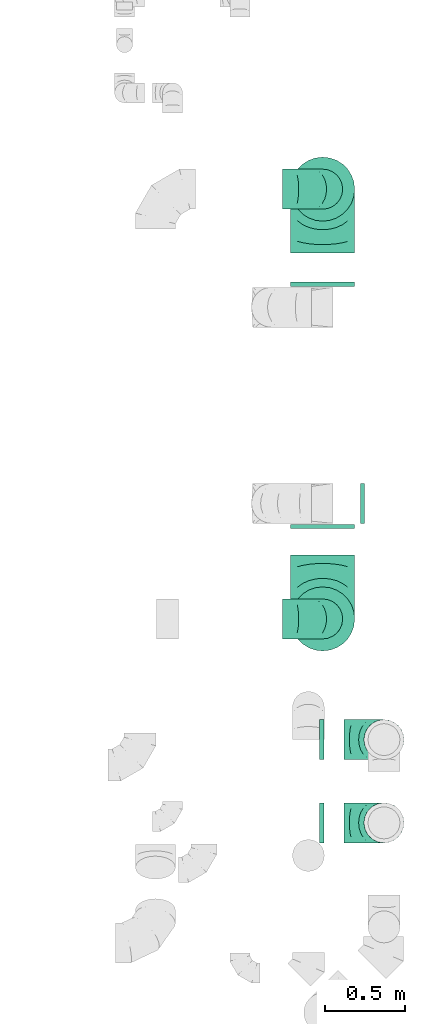
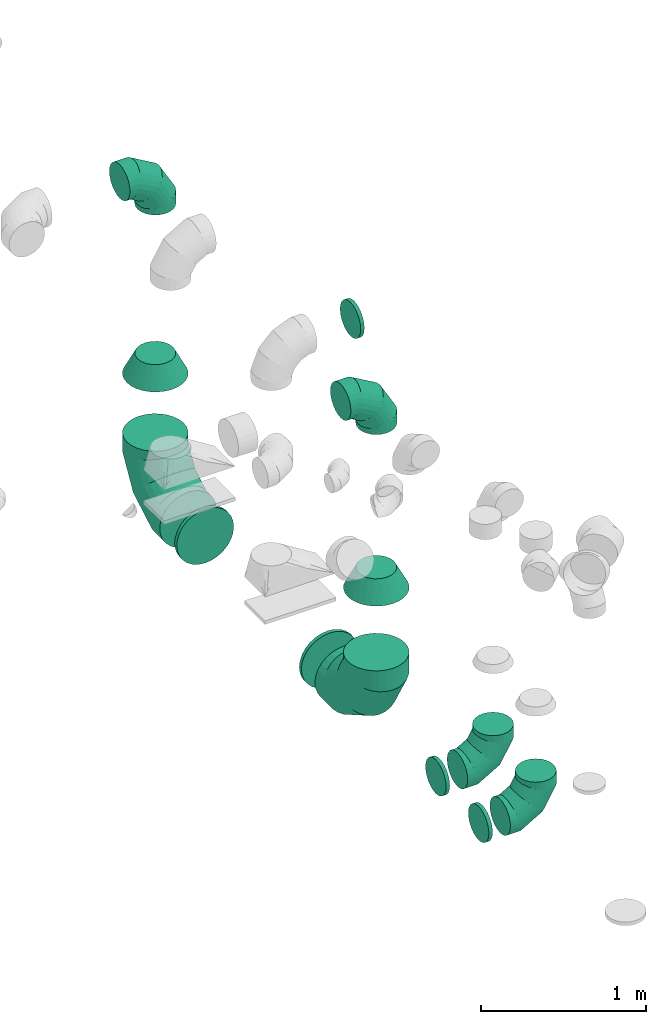
# One storey, part 48 of 59: 13 flow fittings.
"""IFC2X3 building model written with IfcOpenShell, lengths in millimetres."""

from ifc_helpers import new_model, entity, si_unit, converted_unit, derived_unit, direction, frame, origin, place, context, subcontext, project, spatial, faceted_brep, source, transform, mapped, material, type_object, type_shapes, element, save


model = new_model("IFC2X3")

# Units and contexts
model_context = context("Model", 3, precision=0.01, world=origin(), true_north=direction((6.12303176911189e-17, 1.0)))
body_context = subcontext(model_context, "Body", "Model", "MODEL_VIEW")
ifc_project = project(units=[si_unit("LENGTHUNIT", "METRE", prefix="MILLI"), si_unit("AREAUNIT", "SQUARE_METRE"), si_unit("VOLUMEUNIT", "CUBIC_METRE"), converted_unit("PLANEANGLEUNIT", "DEGREE", entity("IfcRatioMeasure", 0.0174532925199433), si_unit("PLANEANGLEUNIT", "RADIAN"), dimensions=[0, 0, 0, 0, 0, 0, 0]), si_unit("MASSUNIT", "GRAM", prefix="KILO"), derived_unit("MASSDENSITYUNIT", [(si_unit("MASSUNIT", "GRAM", prefix="KILO"), 1), (si_unit("LENGTHUNIT", "METRE"), -3)]), derived_unit("MOMENTOFINERTIAUNIT", [(si_unit("LENGTHUNIT", "METRE"), 4)]), si_unit("TIMEUNIT", "SECOND"), si_unit("FREQUENCYUNIT", "HERTZ"), si_unit("THERMODYNAMICTEMPERATUREUNIT", "DEGREE_CELSIUS"), derived_unit("THERMALTRANSMITTANCEUNIT", [(si_unit("MASSUNIT", "GRAM", prefix="KILO"), 1), (si_unit("THERMODYNAMICTEMPERATUREUNIT", "KELVIN"), -1), (si_unit("TIMEUNIT", "SECOND"), -3)]), derived_unit("VOLUMETRICFLOWRATEUNIT", [(si_unit("LENGTHUNIT", "METRE"), 3), (si_unit("TIMEUNIT", "SECOND"), -1)]), derived_unit("MASSFLOWRATEUNIT", [(si_unit("MASSUNIT", "GRAM", prefix="KILO"), 1), (si_unit("TIMEUNIT", "SECOND"), -1)]), derived_unit("ROTATIONALFREQUENCYUNIT", [(si_unit("TIMEUNIT", "SECOND"), -1)]), si_unit("ELECTRICCURRENTUNIT", "AMPERE"), si_unit("ELECTRICVOLTAGEUNIT", "VOLT"), si_unit("POWERUNIT", "WATT"), si_unit("FORCEUNIT", "NEWTON", prefix="KILO"), si_unit("ILLUMINANCEUNIT", "LUX"), si_unit("LUMINOUSFLUXUNIT", "LUMEN"), si_unit("LUMINOUSINTENSITYUNIT", "CANDELA"), derived_unit("USERDEFINED", [(si_unit("MASSUNIT", "GRAM", prefix="KILO"), -1), (si_unit("LENGTHUNIT", "METRE"), -2), (si_unit("TIMEUNIT", "SECOND"), 3), (si_unit("LUMINOUSFLUXUNIT", "LUMEN"), 1)]), derived_unit("LINEARVELOCITYUNIT", [(si_unit("LENGTHUNIT", "METRE"), 1), (si_unit("TIMEUNIT", "SECOND"), -1)]), si_unit("PRESSUREUNIT", "PASCAL"), derived_unit("USERDEFINED", [(si_unit("LENGTHUNIT", "METRE"), -2), (si_unit("MASSUNIT", "GRAM", prefix="KILO"), 1), (si_unit("TIMEUNIT", "SECOND"), -2)]), derived_unit("LINEARFORCEUNIT", [(si_unit("MASSUNIT", "GRAM", prefix="KILO"), 1), (si_unit("LENGTHUNIT", "METRE"), 1), (si_unit("TIMEUNIT", "SECOND"), -2), (si_unit("LENGTHUNIT", "METRE"), -1)]), derived_unit("PLANARFORCEUNIT", [(si_unit("MASSUNIT", "GRAM", prefix="KILO"), 1), (si_unit("LENGTHUNIT", "METRE"), 1), (si_unit("TIMEUNIT", "SECOND"), -2), (si_unit("LENGTHUNIT", "METRE"), -2)])], contexts=[model_context])

# Site, building, storey
site_placement = place(None, origin())
site = spatial("IfcSite", under=ifc_project, at=site_placement, CompositionType="ELEMENT")
building_placement = place(site_placement, origin())
building = spatial("IfcBuilding", under=site, at=building_placement, CompositionType="ELEMENT")
storey_placement = place(building_placement, frame((0.0, 0.0, 28200.0)))
storey = spatial("IfcBuildingStorey", under=building, at=storey_placement, CompositionType="ELEMENT", Elevation=28200.0)

# Flow fittings
ifc_material = material()
duct_fitting_type_1 = type_object("IfcDuctFittingType", PredefinedType="NOTDEFINED", material=ifc_material)
shared_shape_1 = source(origin(), body_context, "Body", "Brep", [
    faceted_brep([(-250.0, 0.0, -125.0), (-250.0, -32.35, -120.74), (-250.0, -62.5, -108.25), (-250.0, -88.39, -88.39), (-250.0, -108.25, -62.5), (-250.0, -120.74, -32.35), (-250.0, -125.0, 0.0), (-250.0, -120.74, 32.35), (-250.0, -108.25, 62.5), (-250.0, -88.39, 88.39), (-250.0, -62.5, 108.25), (-250.0, -32.35, 120.74), (-250.0, 0.0, 125.0), (-250.0, 32.35, 120.74), (-250.0, 62.5, 108.25), (-250.0, 88.39, 88.39), (-250.0, 108.25, 62.5), (-250.0, 120.74, 32.35), (-250.0, 125.0, 0.0), (-250.0, 120.74, -32.35), (-250.0, 108.25, -62.5), (-250.0, 88.39, -88.39), (-250.0, 62.5, -108.25), (-250.0, 32.35, -120.74), (-191.68, 32.35, 120.74), (-199.76, 62.5, 108.25), (-183.01, 0.0, 125.0), (-206.7, 88.39, 88.39), (-215.37, 120.74, 32.35), (-216.51, 125.0, 0.0), (-212.02, 108.25, 62.5), (-212.02, 108.25, -62.5), (-206.7, 88.39, -88.39), (-215.37, 120.74, -32.35), (-191.68, 32.35, -120.74), (-183.01, 0.0, -125.0), (-199.76, 62.5, -108.25), (-174.34, -32.35, -120.74), (-166.27, -62.5, -108.25), (-159.33, -88.39, -88.39), (-154.01, -108.25, -62.5), (-150.66, -120.74, -32.35), (-149.52, -125.0, 0.0), (-150.66, -120.74, 32.35), (-154.01, -108.25, 62.5), (-159.33, -88.39, 88.39), (-166.27, -62.5, 108.25), (-174.34, -32.35, 120.74), (-90.67, 90.67, 120.74), (-112.74, 112.74, 108.25), (-66.99, 66.99, 125.0), (-131.69, 131.69, 88.39), (-146.23, 146.23, 62.5), (-155.38, 155.38, 32.35), (-158.49, 158.49, 0.0), (-155.38, 155.38, -32.35), (-146.23, 146.23, -62.5), (-131.69, 131.69, -88.39), (-90.67, 90.67, -120.74), (-66.99, 66.99, -125.0), (-112.74, 112.74, -108.25), (-43.3, 43.3, -120.74), (-21.23, 21.23, -108.25), (-2.28, 2.28, -88.39), (12.26, -12.26, -62.5), (21.4, -21.4, -32.35), (24.52, -24.52, 0.0), (21.4, -21.4, 32.35), (12.26, -12.26, 62.5), (-2.28, 2.28, 88.39), (-21.23, 21.23, 108.25), (-43.3, 43.3, 120.74), (-32.35, 191.68, 120.74), (-62.5, 199.76, 108.25), (0.0, 183.01, 125.0), (-88.39, 206.7, 88.39), (-108.25, 212.02, 62.5), (-120.74, 215.37, 32.35), (-125.0, 216.51, 0.0), (-120.74, 215.37, -32.35), (-108.25, 212.02, -62.5), (-88.39, 206.7, -88.39), (-32.35, 191.68, -120.74), (0.0, 183.01, -125.0), (-62.5, 199.76, -108.25), (32.35, 174.34, -120.74), (62.5, 166.27, -108.25), (88.39, 159.33, -88.39), (108.25, 154.01, -62.5), (120.74, 150.66, -32.35), (125.0, 149.52, 0.0), (120.74, 150.66, 32.35), (108.25, 154.01, 62.5), (88.39, 159.33, 88.39), (62.5, 166.27, 108.25), (32.35, 174.34, 120.74), (-32.35, 250.0, -120.74), (-62.5, 250.0, -108.25), (-88.39, 250.0, -88.39), (-108.25, 250.0, -62.5), (-120.74, 250.0, -32.35), (-125.0, 250.0, 0.0), (-120.74, 250.0, 32.35), (-108.25, 250.0, 62.5), (-88.39, 250.0, 88.39), (-62.5, 250.0, 108.25), (-32.35, 250.0, 120.74), (0.0, 250.0, 125.0), (32.35, 250.0, 120.74), (62.5, 250.0, 108.25), (88.39, 250.0, 88.39), (108.25, 250.0, 62.5), (120.74, 250.0, 32.35), (125.0, 250.0, 0.0), (120.74, 250.0, -32.35), (108.25, 250.0, -62.5), (88.39, 250.0, -88.39), (62.5, 250.0, -108.25), (32.35, 250.0, -120.74), (0.0, 250.0, -125.0)], [[[0, 1, 2, 3, 4, 5, 6, 7, 8, 9, 10, 11, 12, 13, 14, 15, 16, 17, 18, 19, 20, 21, 22, 23]], [[24, 25, 14, 13]], [[26, 24, 13, 12]], [[14, 25, 27, 15]], [[28, 29, 18, 17]], [[30, 28, 17, 16]], [[15, 27, 30, 16]], [[20, 31, 32, 21]], [[33, 31, 20, 19]], [[18, 29, 33, 19]], [[34, 35, 0, 23]], [[36, 34, 23, 22]], [[21, 32, 36, 22]], [[1, 0, 35, 37]], [[2, 1, 37, 38]], [[38, 39, 3, 2]], [[5, 4, 40, 41]], [[6, 5, 41, 42]], [[39, 40, 4, 3]], [[6, 42, 43, 7]], [[7, 43, 44, 8]], [[8, 44, 45, 9]], [[9, 45, 46, 10]], [[10, 46, 47, 11]], [[26, 12, 11, 47]], [[48, 49, 25, 24]], [[50, 48, 24, 26]], [[27, 25, 49, 51]], [[52, 53, 28, 30]], [[51, 52, 30, 27]], [[29, 28, 53, 54]], [[55, 56, 31, 33]], [[54, 55, 33, 29]], [[32, 31, 56, 57]], [[58, 59, 35, 34]], [[60, 58, 34, 36]], [[57, 60, 36, 32]], [[37, 35, 59, 61]], [[38, 37, 61, 62]], [[39, 38, 62, 63]], [[41, 40, 64, 65]], [[42, 41, 65, 66]], [[63, 64, 40, 39]], [[43, 42, 66, 67]], [[44, 43, 67, 68]], [[68, 69, 45, 44]], [[46, 45, 69, 70]], [[47, 46, 70, 71]], [[26, 47, 71, 50]], [[72, 73, 49, 48]], [[74, 72, 48, 50]], [[51, 49, 73, 75]], [[76, 77, 53, 52]], [[75, 76, 52, 51]], [[54, 53, 77, 78]], [[79, 80, 56, 55]], [[78, 79, 55, 54]], [[57, 56, 80, 81]], [[82, 83, 59, 58]], [[84, 82, 58, 60]], [[81, 84, 60, 57]], [[61, 59, 83, 85]], [[62, 61, 85, 86]], [[63, 62, 86, 87]], [[65, 64, 88, 89]], [[66, 65, 89, 90]], [[87, 88, 64, 63]], [[67, 66, 90, 91]], [[68, 67, 91, 92]], [[92, 93, 69, 68]], [[70, 69, 93, 94]], [[71, 70, 94, 95]], [[50, 71, 95, 74]], [[96, 97, 98, 99, 100, 101, 102, 103, 104, 105, 106, 107, 108, 109, 110, 111, 112, 113, 114, 115, 116, 117, 118, 119]], [[72, 74, 107, 106]], [[73, 72, 106, 105]], [[75, 73, 105, 104]], [[77, 76, 103, 102]], [[78, 77, 102, 101]], [[75, 104, 103, 76]], [[78, 101, 100, 79]], [[79, 100, 99, 80]], [[80, 99, 98, 81]], [[84, 97, 96, 82]], [[82, 96, 119, 83]], [[84, 81, 98, 97]], [[83, 119, 118, 85]], [[85, 118, 117, 86]], [[116, 87, 86, 117]], [[88, 115, 114, 89]], [[89, 114, 113, 90]], [[115, 88, 87, 116]], [[91, 90, 113, 112]], [[92, 91, 112, 111]], [[111, 110, 93, 92]], [[95, 94, 109, 108]], [[74, 95, 108, 107]], [[110, 109, 94, 93]]]),
])
type_shapes(duct_fitting_type_1, [shared_shape_1])
for number, where, z_axis, x_axis in (
    (1, (72711.81, 13945.86, 3000.0), (0.0, 1.0, 0.0), (1.0, 0.0, 0.0)),
    (2, (72711.81, 11260.58, 3000.0), (0.0, -1.0, 0.0), (0.0, 0.0, 1.0)),
    (3, (73094.97, 10506.36, 590.0), (0.0, 1.0, 0.0), (0.0, 0.0, -1.0)),
    (4, (73094.97, 9986.36, 560.0), (0.0, 1.0, 0.0), (0.0, 0.0, -1.0)),
):
    element("IfcFlowFitting", number, at=place(storey_placement, frame(where, z_axis=z_axis, x_axis=x_axis)), inside=storey, type_object=duct_fitting_type_1, material=ifc_material, context=body_context, shape_type="MappedRepresentation", body=[
        mapped(shared_shape_1, transform((0.0, 0.0, 0.0), scale=1.0)),
    ])
duct_fitting_type_2 = type_object("IfcDuctFittingType", PredefinedType="NOTDEFINED", material=ifc_material)
shared_shape_2 = source(origin(), body_context, "Body", "Brep", [
    faceted_brep([(20.0, 0.0, -125.0), (20.0, 32.35, -120.74), (20.0, 62.5, -108.25), (20.0, 88.39, -88.39), (20.0, 108.25, -62.5), (20.0, 120.74, -32.35), (20.0, 125.0, 0.0), (20.0, 120.74, 32.35), (20.0, 108.25, 62.5), (20.0, 88.39, 88.39), (20.0, 62.5, 108.25), (20.0, 32.35, 120.74), (20.0, 0.0, 125.0), (20.0, -32.35, 120.74), (20.0, -62.5, 108.25), (20.0, -88.39, 88.39), (20.0, -108.25, 62.5), (20.0, -120.74, 32.35), (20.0, -125.0, 0.0), (20.0, -120.74, -32.35), (20.0, -108.25, -62.5), (20.0, -88.39, -88.39), (20.0, -62.5, -108.25), (20.0, -32.35, -120.74), (0.0, 0.0, 125.0), (-6.1, 0.0, 125.0), (-6.1, -32.35, 120.74), (0.0, -32.35, 120.74), (-6.1, -62.5, 108.25), (0.0, -62.5, 108.25), (0.0, -88.39, 88.39), (-6.1, -88.39, 88.39), (0.0, -108.25, 62.5), (-6.1, -108.25, 62.5), (-6.1, -120.74, 32.35), (0.0, -120.74, 32.35), (-6.1, -125.0, 0.0), (0.0, -125.0, 0.0), (-6.1, -120.74, -32.35), (0.0, -120.74, -32.35), (-6.1, -108.25, -62.5), (0.0, -108.25, -62.5), (0.0, -88.39, -88.39), (-6.1, -88.39, -88.39), (0.0, -62.5, -108.25), (-6.1, -62.5, -108.25), (-6.1, -32.35, -120.74), (0.0, -32.35, -120.74), (-6.1, 0.0, -125.0), (0.0, 0.0, -125.0), (-6.1, 32.35, -120.74), (0.0, 32.35, -120.74), (-6.1, 62.5, -108.25), (0.0, 62.5, -108.25), (0.0, 88.39, -88.39), (-6.1, 88.39, -88.39), (0.0, 108.25, -62.5), (-6.1, 108.25, -62.5), (-6.1, 120.74, -32.35), (0.0, 120.74, -32.35), (-6.1, 125.0, 0.0), (0.0, 125.0, 0.0), (-6.1, 120.74, 32.35), (0.0, 120.74, 32.35), (-6.1, 108.25, 62.5), (0.0, 108.25, 62.5), (0.0, 88.39, 88.39), (-6.1, 88.39, 88.39), (0.0, 62.5, 108.25), (-6.1, 62.5, 108.25), (-6.1, 32.35, 120.74), (0.0, 32.35, 120.74)], [[[0, 1, 2, 3, 4, 5, 6, 7, 8, 9, 10, 11, 12, 13, 14, 15, 16, 17, 18, 19, 20, 21, 22, 23]], [[13, 12, 24, 25, 26, 27]], [[14, 13, 27, 26, 28, 29]], [[30, 15, 14, 29, 28, 31]], [[17, 16, 32, 33, 34, 35]], [[18, 17, 35, 34, 36, 37]], [[32, 16, 15, 30, 31, 33]], [[19, 18, 37, 36, 38, 39]], [[20, 19, 39, 38, 40, 41]], [[42, 21, 20, 41, 40, 43]], [[23, 22, 44, 45, 46, 47]], [[0, 23, 47, 46, 48, 49]], [[44, 22, 21, 42, 43, 45]], [[1, 0, 49, 48, 50, 51]], [[2, 1, 51, 50, 52, 53]], [[54, 3, 2, 53, 52, 55]], [[5, 4, 56, 57, 58, 59]], [[6, 5, 59, 58, 60, 61]], [[56, 4, 3, 54, 55, 57]], [[7, 6, 61, 60, 62, 63]], [[8, 7, 63, 62, 64, 65]], [[66, 9, 8, 65, 64, 67]], [[11, 10, 68, 69, 70, 71]], [[12, 11, 71, 70, 25, 24]], [[68, 10, 9, 66, 67, 69]], [[46, 45, 43, 40, 38, 36, 34, 33, 31, 28, 26, 25, 70, 69, 67, 64, 62, 60, 58, 57, 55, 52, 50, 48]]]),
])
type_shapes(duct_fitting_type_2, [shared_shape_2])
flow_fitting_placement = place(storey_placement, frame((72966.81, 11982.7, 2999.92), z_axis=(-0.000703285451190477, 0.0, -0.999999752694756), x_axis=(-0.999999752694756, 0.0, 0.000703285451182642)))
element("IfcFlowFitting", 5, at=flow_fitting_placement, inside=storey, type_object=duct_fitting_type_2, material=ifc_material, context=body_context, shape_type="MappedRepresentation", body=[
    mapped(shared_shape_2, transform((0.0, 0.0, 0.0), scale=1.0)),
])
duct_fitting_type_3 = type_object("IfcDuctFittingType", PredefinedType="NOTDEFINED", material=ifc_material)
type_shapes(duct_fitting_type_3, [shared_shape_2])
for number, where, z_axis, x_axis in (
    (6, (72699.6, 10506.36, 590.0), (0.0, 0.0, -1.0), (1.0, 0.0, 0.0)),
    (7, (72699.6, 9986.36, 560.0), (0.0, 0.0, -1.0), (1.0, 0.0, 0.0)),
):
    element("IfcFlowFitting", number, at=place(storey_placement, frame(where, z_axis=z_axis, x_axis=x_axis)), inside=storey, type_object=duct_fitting_type_3, material=ifc_material, context=body_context, shape_type="MappedRepresentation", body=[
        mapped(shared_shape_2, transform((0.0, 0.0, 0.0), scale=1.0)),
    ])
duct_fitting_type_4 = type_object("IfcDuctFittingType", PredefinedType="NOTDEFINED", material=ifc_material)
shared_shape_3 = source(origin(), body_context, "Body", "Brep", [
    faceted_brep([(-400.0, 0.0, -200.0), (-400.0, -44.5, -194.99), (-400.0, -86.78, -180.19), (-400.0, -124.7, -156.37), (-400.0, -156.37, -124.7), (-400.0, -180.19, -86.78), (-400.0, -194.99, -44.5), (-400.0, -200.0, 0.0), (-400.0, -194.99, 44.5), (-400.0, -180.19, 86.78), (-400.0, -156.37, 124.7), (-400.0, -124.7, 156.37), (-400.0, -86.78, 180.19), (-400.0, -44.5, 194.99), (-400.0, 0.0, 200.0), (-400.0, 44.5, 194.99), (-400.0, 86.78, 180.19), (-400.0, 124.7, 156.37), (-400.0, 156.37, 124.7), (-400.0, 180.19, 86.78), (-400.0, 194.99, 44.5), (-400.0, 200.0, 0.0), (-400.0, 194.99, -44.5), (-400.0, 180.19, -86.78), (-400.0, 156.37, -124.7), (-400.0, 124.7, -156.37), (-400.0, 86.78, -180.19), (-400.0, 44.5, -194.99), (-292.82, 0.0, 200.0), (-304.75, 44.5, 194.99), (-316.07, 86.78, 180.19), (-326.23, 124.7, 156.37), (-334.72, 156.37, 124.7), (-341.1, 180.19, 86.78), (-345.07, 194.99, 44.5), (-346.41, 200.0, 0.0), (-345.07, 194.99, -44.5), (-341.1, 180.19, -86.78), (-334.72, 156.37, -124.7), (-326.23, 124.7, -156.37), (-316.07, 86.78, -180.19), (-304.75, 44.5, -194.99), (-292.82, 0.0, -200.0), (-280.9, -44.5, -194.99), (-269.57, -86.78, -180.19), (-259.41, -124.7, -156.37), (-250.92, -156.37, -124.7), (-244.54, -180.19, -86.78), (-240.57, -194.99, -44.5), (-239.23, -200.0, 0.0), (-240.57, -194.99, 44.5), (-244.54, -180.19, 86.78), (-250.92, -156.37, 124.7), (-259.41, -124.7, 156.37), (-269.57, -86.78, 180.19), (-280.9, -44.5, 194.99), (-107.18, 107.18, 200.0), (-139.76, 139.76, 194.99), (-170.7, 170.7, 180.19), (-198.46, 198.46, 156.37), (-221.65, 221.65, 124.7), (-239.09, 239.09, 86.78), (-249.92, 249.92, 44.5), (-253.59, 253.59, 0.0), (-249.92, 249.92, -44.5), (-239.09, 239.09, -86.78), (-221.65, 221.65, -124.7), (-198.46, 198.46, -156.37), (-170.7, 170.7, -180.19), (-139.76, 139.76, -194.99), (-107.18, 107.18, -200.0), (-74.6, 74.6, -194.99), (-43.65, 43.65, -180.19), (-15.89, 15.89, -156.37), (7.29, -7.29, -124.7), (24.73, -24.73, -86.78), (35.56, -35.56, -44.5), (39.23, -39.23, 0.0), (35.56, -35.56, 44.5), (24.73, -24.73, 86.78), (7.29, -7.29, 124.7), (-15.89, 15.89, 156.37), (-43.65, 43.65, 180.19), (-74.6, 74.6, 194.99), (0.0, 292.82, 200.0), (-44.5, 304.75, 194.99), (-86.78, 316.07, 180.19), (-124.7, 326.23, 156.37), (-156.37, 334.72, 124.7), (-180.19, 341.1, 86.78), (-194.99, 345.07, 44.5), (-200.0, 346.41, 0.0), (-194.99, 345.07, -44.5), (-180.19, 341.1, -86.78), (-156.37, 334.72, -124.7), (-124.7, 326.23, -156.37), (-86.78, 316.07, -180.19), (-44.5, 304.75, -194.99), (0.0, 292.82, -200.0), (44.5, 280.9, -194.99), (86.78, 269.57, -180.19), (124.7, 259.41, -156.37), (156.37, 250.92, -124.7), (180.19, 244.54, -86.78), (194.99, 240.57, -44.5), (200.0, 239.23, 0.0), (194.99, 240.57, 44.5), (180.19, 244.54, 86.78), (156.37, 250.92, 124.7), (124.7, 259.41, 156.37), (86.78, 269.57, 180.19), (44.5, 280.9, 194.99), (-44.5, 400.0, -194.99), (-86.78, 400.0, -180.19), (-124.7, 400.0, -156.37), (-156.37, 400.0, -124.7), (-180.19, 400.0, -86.78), (-194.99, 400.0, -44.5), (-200.0, 400.0, 0.0), (-194.99, 400.0, 44.5), (-180.19, 400.0, 86.78), (-156.37, 400.0, 124.7), (-124.7, 400.0, 156.37), (-86.78, 400.0, 180.19), (-44.5, 400.0, 194.99), (0.0, 400.0, 200.0), (44.5, 400.0, 194.99), (86.78, 400.0, 180.19), (124.7, 400.0, 156.37), (156.37, 400.0, 124.7), (180.19, 400.0, 86.78), (194.99, 400.0, 44.5), (200.0, 400.0, 0.0), (194.99, 400.0, -44.5), (180.19, 400.0, -86.78), (156.37, 400.0, -124.7), (124.7, 400.0, -156.37), (86.78, 400.0, -180.19), (44.5, 400.0, -194.99), (0.0, 400.0, -200.0)], [[[0, 1, 2, 3, 4, 5, 6, 7, 8, 9, 10, 11, 12, 13, 14, 15, 16, 17, 18, 19, 20, 21, 22, 23, 24, 25, 26, 27]], [[28, 29, 15, 14]], [[30, 31, 17, 16]], [[29, 30, 16, 15]], [[31, 32, 18, 17]], [[32, 33, 19, 18]], [[34, 35, 21, 20]], [[33, 34, 20, 19]], [[35, 36, 22, 21]], [[37, 38, 24, 23]], [[36, 37, 23, 22]], [[38, 39, 25, 24]], [[39, 40, 26, 25]], [[41, 42, 0, 27]], [[40, 41, 27, 26]], [[1, 0, 42, 43]], [[43, 44, 2, 1]], [[45, 3, 2, 44]], [[45, 46, 4, 3]], [[5, 4, 46, 47]], [[47, 48, 6, 5]], [[49, 7, 6, 48]], [[7, 49, 50, 8]], [[8, 50, 51, 9]], [[9, 51, 52, 10]], [[52, 53, 11, 10]], [[11, 53, 54, 12]], [[12, 54, 55, 13]], [[13, 55, 28, 14]], [[56, 57, 29, 28]], [[58, 59, 31, 30]], [[57, 58, 30, 29]], [[59, 60, 32, 31]], [[60, 61, 33, 32]], [[62, 63, 35, 34]], [[61, 62, 34, 33]], [[63, 64, 36, 35]], [[65, 66, 38, 37]], [[64, 65, 37, 36]], [[66, 67, 39, 38]], [[67, 68, 40, 39]], [[69, 70, 42, 41]], [[68, 69, 41, 40]], [[43, 42, 70, 71]], [[71, 72, 44, 43]], [[73, 45, 44, 72]], [[73, 74, 46, 45]], [[47, 46, 74, 75]], [[75, 76, 48, 47]], [[77, 49, 48, 76]], [[50, 49, 77, 78]], [[51, 50, 78, 79]], [[52, 51, 79, 80]], [[80, 81, 53, 52]], [[54, 53, 81, 82]], [[55, 54, 82, 83]], [[28, 55, 83, 56]], [[84, 85, 57, 56]], [[86, 87, 59, 58]], [[85, 86, 58, 57]], [[87, 88, 60, 59]], [[88, 89, 61, 60]], [[90, 91, 63, 62]], [[89, 90, 62, 61]], [[91, 92, 64, 63]], [[93, 94, 66, 65]], [[92, 93, 65, 64]], [[94, 95, 67, 66]], [[95, 96, 68, 67]], [[97, 98, 70, 69]], [[96, 97, 69, 68]], [[71, 70, 98, 99]], [[99, 100, 72, 71]], [[101, 73, 72, 100]], [[101, 102, 74, 73]], [[75, 74, 102, 103]], [[103, 104, 76, 75]], [[105, 77, 76, 104]], [[78, 77, 105, 106]], [[79, 78, 106, 107]], [[80, 79, 107, 108]], [[108, 109, 81, 80]], [[82, 81, 109, 110]], [[83, 82, 110, 111]], [[56, 83, 111, 84]], [[112, 113, 114, 115, 116, 117, 118, 119, 120, 121, 122, 123, 124, 125, 126, 127, 128, 129, 130, 131, 132, 133, 134, 135, 136, 137, 138, 139]], [[85, 84, 125, 124]], [[86, 85, 124, 123]], [[87, 86, 123, 122]], [[122, 121, 88, 87]], [[89, 88, 121, 120]], [[90, 89, 120, 119]], [[91, 90, 119, 118]], [[91, 118, 117, 92]], [[92, 117, 116, 93]], [[93, 116, 115, 94]], [[115, 114, 95, 94]], [[95, 114, 113, 96]], [[96, 113, 112, 97]], [[97, 112, 139, 98]], [[98, 139, 138, 99]], [[99, 138, 137, 100]], [[100, 137, 136, 101]], [[136, 135, 102, 101]], [[102, 135, 134, 103]], [[103, 134, 133, 104]], [[104, 133, 132, 105]], [[106, 105, 132, 131]], [[107, 106, 131, 130]], [[108, 107, 130, 129]], [[129, 128, 109, 108]], [[110, 109, 128, 127]], [[111, 110, 127, 126]], [[84, 111, 126, 125]]]),
])
type_shapes(duct_fitting_type_4, [shared_shape_3])
for number, where, z_axis, x_axis in (
    (8, (72711.81, 11260.58, 650.0), (1.0, 0.0, 0.0), (0.0, 0.0, -1.0)),
    (9, (72711.81, 13945.86, 650.0), (-1.0, 0.0, 0.0), (0.0, 0.0, -1.0)),
):
    element("IfcFlowFitting", number, at=place(storey_placement, frame(where, z_axis=z_axis, x_axis=x_axis)), inside=storey, type_object=duct_fitting_type_4, material=ifc_material, context=body_context, shape_type="MappedRepresentation", body=[
        mapped(shared_shape_3, transform((0.0, 0.0, 0.0), scale=1.0)),
    ])
duct_fitting_type_5 = type_object("IfcDuctFittingType", PredefinedType="NOTDEFINED", material=ifc_material)
shared_shape_4 = source(origin(), body_context, "Body", "Brep", [
    faceted_brep([(20.0, 200.0, 0.0), (20.0, 194.99, 44.5), (20.0, 180.19, 86.78), (20.0, 156.37, 124.7), (20.0, 124.7, 156.37), (20.0, 86.78, 180.19), (20.0, 44.5, 194.99), (20.0, 0.0, 200.0), (20.0, -44.5, 194.99), (20.0, -86.78, 180.19), (20.0, -124.7, 156.37), (20.0, -156.37, 124.7), (20.0, -180.19, 86.78), (20.0, -194.99, 44.5), (20.0, -200.0, 0.0), (20.0, -194.99, -44.5), (20.0, -180.19, -86.78), (20.0, -156.37, -124.7), (20.0, -124.7, -156.37), (20.0, -86.78, -180.19), (20.0, -44.5, -194.99), (20.0, 0.0, -200.0), (20.0, 44.5, -194.99), (20.0, 86.78, -180.19), (20.0, 124.7, -156.37), (20.0, 156.37, -124.7), (20.0, 180.19, -86.78), (20.0, 194.99, -44.5), (0.0, 0.0, 200.0), (0.0, 30.6, 196.55), (-6.1, 22.25, 197.49), (-6.1, 0.0, 200.0), (0.0, 44.5, 194.99), (-6.1, 44.5, 194.99), (0.0, 65.64, 187.59), (0.0, 86.78, 180.19), (-6.1, 65.64, 187.59), (-6.1, 86.78, 180.19), (0.0, 105.74, 168.28), (0.0, 124.7, 156.37), (-6.1, 105.74, 168.28), (-6.1, 124.7, 156.37), (0.0, 140.53, 140.53), (0.0, 156.37, 124.7), (-6.1, 140.53, 140.53), (-6.1, 156.37, 124.7), (0.0, 168.28, 105.74), (0.0, 180.19, 86.78), (-6.1, 168.28, 105.74), (-6.1, 180.19, 86.78), (0.0, 187.59, 65.64), (0.0, 194.99, 44.5), (-6.1, 187.59, 65.64), (-6.1, 194.99, 44.5), (0.0, 197.49, 22.25), (0.0, 200.0, 0.0), (-6.1, 200.0, 0.0), (-6.1, 196.55, 30.6), (0.0, 196.55, -30.6), (-6.1, 197.49, -22.25), (0.0, 194.99, -44.5), (-6.1, 194.99, -44.5), (0.0, 187.59, -65.64), (0.0, 180.19, -86.78), (-6.1, 187.59, -65.64), (-6.1, 180.19, -86.78), (0.0, 168.28, -105.74), (0.0, 156.37, -124.7), (-6.1, 168.28, -105.74), (-6.1, 156.37, -124.7), (0.0, 140.53, -140.53), (0.0, 124.7, -156.37), (-6.1, 140.53, -140.53), (-6.1, 124.7, -156.37), (0.0, 105.74, -168.28), (0.0, 86.78, -180.19), (-6.1, 86.78, -180.19), (-6.1, 105.74, -168.28), (0.0, 44.5, -194.99), (0.0, 65.64, -187.59), (-6.1, 44.5, -194.99), (-6.1, 65.64, -187.59), (0.0, 0.0, -200.0), (0.0, 30.6, -196.55), (-6.1, 22.25, -197.49), (-6.1, 0.0, -200.0), (0.0, -30.6, -196.55), (-6.1, -22.25, -197.49), (0.0, -44.5, -194.99), (-6.1, -44.5, -194.99), (0.0, -65.64, -187.59), (0.0, -86.78, -180.19), (-6.1, -65.64, -187.59), (-6.1, -86.78, -180.19), (0.0, -105.74, -168.28), (0.0, -124.7, -156.37), (-6.1, -105.74, -168.28), (-6.1, -124.7, -156.37), (0.0, -140.53, -140.53), (0.0, -156.37, -124.7), (-6.1, -140.53, -140.53), (-6.1, -156.37, -124.7), (0.0, -168.28, -105.74), (0.0, -180.19, -86.78), (-6.1, -168.28, -105.74), (-6.1, -180.19, -86.78), (0.0, -194.99, -44.5), (0.0, -196.55, -30.6), (0.0, -200.0, 0.0), (-6.1, -197.49, -22.25), (-6.1, -200.0, 0.0), (-6.1, -194.99, -44.5), (0.0, -187.59, -65.64), (-6.1, -187.59, -65.64), (0.0, -196.55, 30.6), (-6.1, -197.49, 22.25), (0.0, -194.99, 44.5), (-6.1, -194.99, 44.5), (0.0, -187.59, 65.64), (0.0, -180.19, 86.78), (-6.1, -187.59, 65.64), (-6.1, -180.19, 86.78), (0.0, -168.28, 105.74), (0.0, -156.37, 124.7), (-6.1, -168.28, 105.74), (-6.1, -156.37, 124.7), (0.0, -140.53, 140.53), (0.0, -124.7, 156.37), (-6.1, -140.53, 140.53), (-6.1, -124.7, 156.37), (0.0, -105.74, 168.28), (0.0, -86.78, 180.19), (-6.1, -105.74, 168.28), (-6.1, -86.78, 180.19), (0.0, -65.64, 187.59), (0.0, -44.5, 194.99), (-6.1, -65.64, 187.59), (-6.1, -44.5, 194.99), (0.0, -22.25, 197.49), (-6.1, -30.6, 196.55)], [[[0, 1, 2, 3, 4, 5, 6, 7, 8, 9, 10, 11, 12, 13, 14, 15, 16, 17, 18, 19, 20, 21, 22, 23, 24, 25, 26, 27]], [[28, 7, 6]], [[6, 29, 28]], [[28, 29, 30]], [[31, 28, 30]], [[6, 32, 29]], [[32, 33, 29]], [[29, 33, 30]], [[6, 5, 32]], [[5, 34, 32]], [[5, 35, 34]], [[36, 34, 35]], [[35, 37, 36]], [[33, 34, 36]], [[34, 33, 32]], [[4, 35, 5]], [[4, 38, 35]], [[4, 39, 38]], [[38, 39, 40]], [[39, 41, 40]], [[37, 38, 40]], [[38, 37, 35]], [[4, 3, 39]], [[3, 42, 39]], [[3, 43, 42]], [[44, 42, 43]], [[43, 45, 44]], [[41, 42, 44]], [[39, 42, 41]], [[43, 3, 2]], [[2, 46, 43]], [[45, 43, 46]], [[2, 47, 46]], [[47, 48, 46]], [[47, 49, 48]], [[45, 46, 48]], [[2, 1, 47]], [[1, 50, 47]], [[1, 51, 50]], [[52, 50, 51]], [[51, 53, 52]], [[49, 50, 52]], [[50, 49, 47]], [[0, 51, 1]], [[0, 54, 51]], [[0, 55, 54]], [[55, 56, 54]], [[56, 57, 54]], [[57, 51, 54]], [[51, 57, 53]], [[55, 0, 27]], [[27, 58, 55]], [[55, 58, 59]], [[56, 55, 59]], [[27, 60, 58]], [[60, 61, 58]], [[58, 61, 59]], [[27, 26, 60]], [[26, 62, 60]], [[26, 63, 62]], [[64, 62, 63]], [[63, 65, 64]], [[61, 62, 64]], [[62, 61, 60]], [[25, 63, 26]], [[25, 66, 63]], [[25, 67, 66]], [[66, 67, 68]], [[67, 69, 68]], [[65, 66, 68]], [[66, 65, 63]], [[25, 24, 67]], [[24, 70, 67]], [[24, 71, 70]], [[72, 70, 71]], [[71, 73, 72]], [[69, 70, 72]], [[67, 70, 69]], [[24, 23, 71]], [[23, 74, 71]], [[23, 75, 74]], [[74, 75, 76]], [[76, 77, 74]], [[73, 74, 77]], [[73, 71, 74]], [[23, 22, 78]], [[23, 78, 79]], [[23, 79, 75]], [[79, 78, 80]], [[79, 80, 81]], [[81, 75, 79]], [[75, 81, 76]], [[82, 22, 21]], [[22, 82, 83]], [[82, 84, 83]], [[82, 85, 84]], [[80, 83, 84]], [[83, 80, 78]], [[22, 83, 78]], [[82, 21, 20]], [[20, 86, 82]], [[82, 86, 87]], [[85, 82, 87]], [[20, 88, 86]], [[88, 89, 86]], [[86, 89, 87]], [[20, 19, 88]], [[19, 90, 88]], [[19, 91, 90]], [[92, 90, 91]], [[91, 93, 92]], [[89, 90, 92]], [[90, 89, 88]], [[18, 91, 19]], [[18, 94, 91]], [[18, 95, 94]], [[94, 95, 96]], [[95, 97, 96]], [[93, 94, 96]], [[94, 93, 91]], [[18, 17, 95]], [[17, 98, 95]], [[17, 99, 98]], [[100, 98, 99]], [[99, 101, 100]], [[97, 98, 100]], [[95, 98, 97]], [[17, 16, 99]], [[16, 102, 99]], [[16, 103, 102]], [[103, 104, 102]], [[103, 105, 104]], [[101, 102, 104]], [[101, 99, 102]], [[15, 14, 106]], [[14, 107, 106]], [[14, 108, 107]], [[108, 109, 107]], [[108, 110, 109]], [[111, 107, 109]], [[107, 111, 106]], [[16, 15, 106]], [[16, 106, 112]], [[16, 112, 103]], [[112, 106, 111]], [[112, 111, 113]], [[103, 113, 105]], [[113, 103, 112]], [[108, 14, 13]], [[13, 114, 108]], [[108, 114, 115]], [[110, 108, 115]], [[13, 116, 114]], [[116, 117, 114]], [[114, 117, 115]], [[13, 12, 116]], [[12, 118, 116]], [[12, 119, 118]], [[120, 118, 119]], [[119, 121, 120]], [[117, 118, 120]], [[118, 117, 116]], [[11, 119, 12]], [[11, 122, 119]], [[11, 123, 122]], [[122, 123, 124]], [[123, 125, 124]], [[121, 122, 124]], [[122, 121, 119]], [[11, 10, 123]], [[10, 126, 123]], [[10, 127, 126]], [[128, 126, 127]], [[127, 129, 128]], [[125, 126, 128]], [[123, 126, 125]], [[127, 10, 9]], [[9, 130, 127]], [[129, 127, 130]], [[9, 131, 130]], [[131, 132, 130]], [[131, 133, 132]], [[129, 130, 132]], [[9, 8, 131]], [[8, 134, 131]], [[8, 135, 134]], [[136, 134, 135]], [[135, 137, 136]], [[133, 134, 136]], [[134, 133, 131]], [[7, 135, 8]], [[7, 138, 135]], [[7, 28, 138]], [[28, 31, 138]], [[31, 139, 138]], [[139, 135, 138]], [[135, 139, 137]], [[87, 89, 92, 93, 96, 97, 100, 101, 104, 105, 113, 111, 109, 110, 115, 117, 120, 121, 124, 125, 128, 129, 132, 133, 136, 137, 139, 31, 30, 33, 36, 37, 40, 41, 44, 45, 48, 49, 52, 53, 57, 56, 59, 61, 64, 65, 68, 69, 72, 73, 77, 76, 81, 80, 84, 85]]]),
])
type_shapes(duct_fitting_type_5, [shared_shape_4])
for number, where, z_axis, x_axis in (
    (10, (72711.81, 11845.08, 650.0), (0.0, 0.0, -1.0), (0.0, -1.0, 0.0)),
    (11, (72711.81, 13345.08, 650.0), (0.0, 0.0, 1.0), (0.0, 1.0, 0.0)),
):
    element("IfcFlowFitting", number, at=place(storey_placement, frame(where, z_axis=z_axis, x_axis=x_axis)), inside=storey, type_object=duct_fitting_type_5, material=ifc_material, context=body_context, shape_type="MappedRepresentation", body=[
        mapped(shared_shape_4, transform((0.0, 0.0, 0.0), scale=1.0)),
    ])
duct_fitting_type_6 = type_object("IfcDuctFittingType", PredefinedType="NOTDEFINED", material=ifc_material)
shared_shape_5 = source(origin(), body_context, "Body", "Brep", [
    faceted_brep([(150.0, -86.78, -180.19), (150.0, -44.5, -194.99), (150.0, 0.0, -200.0), (150.0, 44.5, -194.99), (150.0, 86.78, -180.19), (150.0, 124.7, -156.37), (150.0, 156.37, -124.7), (150.0, 180.19, -86.78), (150.0, 194.99, -44.5), (150.0, 200.0, 0.0), (150.0, 194.99, 44.5), (150.0, 180.19, 86.78), (150.0, 156.37, 124.7), (150.0, 124.7, 156.37), (150.0, 86.78, 180.19), (150.0, 44.5, 194.99), (150.0, 0.0, 200.0), (150.0, -44.5, 194.99), (150.0, -86.78, 180.19), (150.0, -124.7, 156.37), (150.0, -156.37, 124.7), (150.0, -180.19, 86.78), (150.0, -194.99, 44.5), (150.0, -200.0, 0.0), (150.0, -194.99, -44.5), (150.0, -180.19, -86.78), (150.0, -156.37, -124.7), (150.0, -124.7, -156.37), (0.0, 38.63, -118.88), (0.0, 0.0, -125.0), (0.0, -38.63, -118.88), (0.0, -73.47, -101.13), (0.0, -101.13, -73.47), (0.0, -118.88, -38.63), (0.0, -125.0, 0.0), (0.0, -118.88, 38.63), (0.0, -101.13, 73.47), (0.0, -73.47, 101.13), (0.0, -38.63, 118.88), (0.0, 0.0, 125.0), (0.0, 38.63, 118.88), (0.0, 73.47, 101.13), (0.0, 101.13, 73.47), (0.0, 118.88, 38.63), (0.0, 125.0, 0.0), (0.0, 118.88, -38.63), (0.0, 101.13, -73.47), (0.0, 73.47, -101.13)], [[[0, 1, 2, 3, 4, 5, 6, 7, 8, 9, 10, 11, 12, 13, 14, 15, 16, 17, 18, 19, 20, 21, 22, 23, 24, 25, 26, 27]], [[28, 29, 30, 31, 32, 33, 34, 35, 36, 37, 38, 39, 40, 41, 42, 43, 44, 45, 46, 47]], [[10, 44, 43]], [[11, 43, 42]], [[10, 9, 44]], [[12, 11, 42]], [[10, 43, 11]], [[42, 41, 13, 12]], [[40, 39, 15]], [[41, 40, 14]], [[13, 41, 14]], [[14, 40, 15]], [[39, 16, 15]], [[17, 39, 38]], [[18, 38, 37]], [[17, 16, 39]], [[19, 18, 37]], [[17, 38, 18]], [[37, 36, 20, 19]], [[35, 34, 22]], [[36, 35, 21]], [[20, 36, 21]], [[21, 35, 22]], [[34, 23, 22]], [[24, 34, 33]], [[25, 33, 32]], [[24, 23, 34]], [[26, 25, 32]], [[24, 33, 25]], [[32, 31, 27, 26]], [[30, 29, 1]], [[31, 30, 0]], [[27, 31, 0]], [[0, 30, 1]], [[29, 2, 1]], [[3, 29, 28]], [[4, 28, 47]], [[3, 2, 29]], [[5, 4, 47]], [[3, 28, 4]], [[47, 46, 6, 5]], [[45, 44, 8]], [[46, 45, 7]], [[6, 46, 7]], [[7, 45, 8]], [[44, 9, 8]]]),
])
type_shapes(duct_fitting_type_6, [shared_shape_5])
for number, where, z_axis, x_axis in (
    (12, (72711.81, 13945.86, 1640.0), (1.0, 0.0, 0.0), (0.0, 0.0, -1.0)),
    (13, (72711.81, 11260.58, 1680.0), (1.0, 0.0, 0.0), (0.0, 0.0, -1.0)),
):
    element("IfcFlowFitting", number, at=place(storey_placement, frame(where, z_axis=z_axis, x_axis=x_axis)), inside=storey, type_object=duct_fitting_type_6, material=ifc_material, context=body_context, shape_type="MappedRepresentation", body=[
        mapped(shared_shape_5, transform((0.0, 0.0, 0.0), scale=1.0)),
    ])

save(model, "model.ifc")
